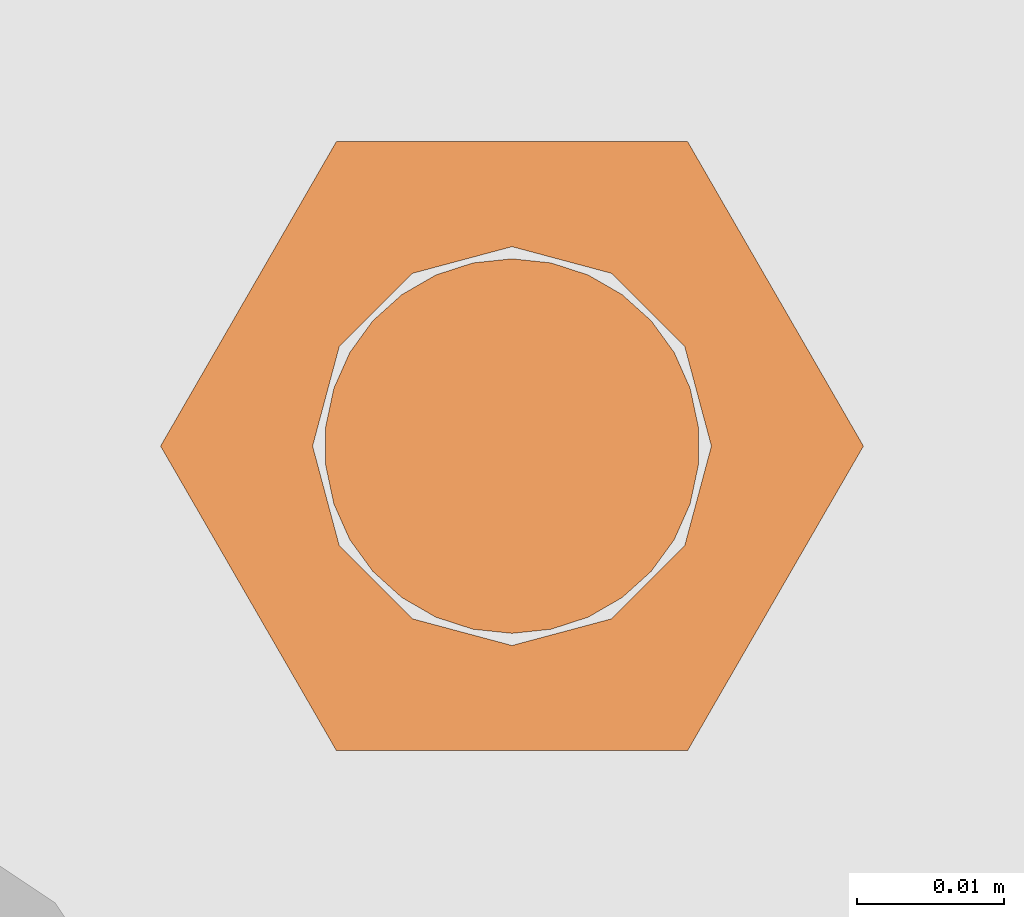
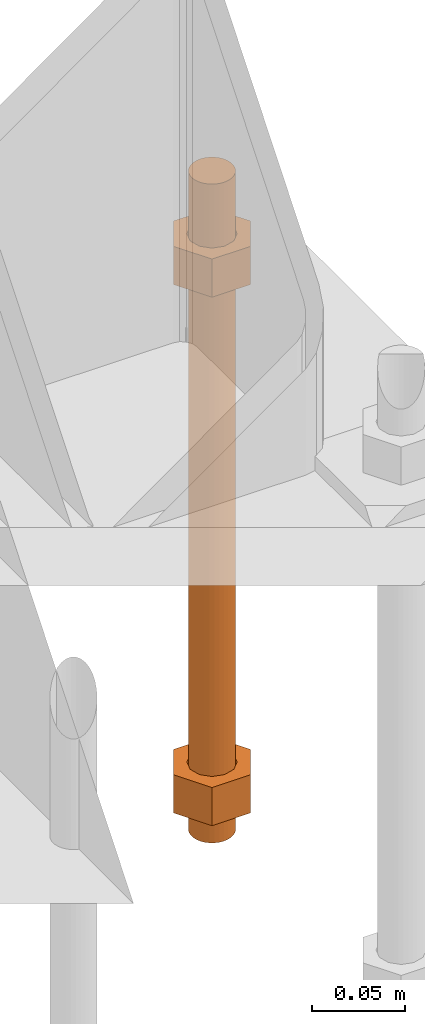
# One storey, part 30 of 89: 1 proxy.
"""IFC4 building model written with IfcOpenShell, lengths in feet."""

from ifc_helpers import new_model, entity, si_unit, converted_unit, derived_unit, direction, frame, origin, place, context, subcontext, project, spatial, faceted_brep, source, transform, mapped, material, constituent, constituent_set, type_object, type_shapes, element, save


model = new_model("IFC4")

# Units and contexts
model_context = context("Model", 3, precision=0.0001, world=origin(), true_north=direction((6.12303176911189e-17, 1.0)))
body_context = subcontext(model_context, "Body", "Model", "MODEL_VIEW")
ifc_project = project(units=[converted_unit("LENGTHUNIT", "FOOT", entity("IfcRatioMeasure", 0.3048), si_unit("LENGTHUNIT", "METRE"), dimensions=[1, 0, 0, 0, 0, 0, 0]), converted_unit("AREAUNIT", "SQUARE FOOT", entity("IfcRatioMeasure", 0.09290304), si_unit("AREAUNIT", "SQUARE_METRE"), dimensions=[2, 0, 0, 0, 0, 0, 0]), converted_unit("VOLUMEUNIT", "CUBIC FOOT", entity("IfcRatioMeasure", 0.028316846592), si_unit("VOLUMEUNIT", "CUBIC_METRE"), dimensions=[3, 0, 0, 0, 0, 0, 0]), si_unit("PLANEANGLEUNIT", "RADIAN"), si_unit("MASSUNIT", "GRAM", prefix="KILO"), derived_unit("MASSDENSITYUNIT", [(si_unit("MASSUNIT", "GRAM", prefix="KILO"), 1), (si_unit("LENGTHUNIT", "METRE"), -3)]), derived_unit("MOMENTOFINERTIAUNIT", [(si_unit("LENGTHUNIT", "METRE"), 4)]), si_unit("TIMEUNIT", "SECOND"), si_unit("FREQUENCYUNIT", "HERTZ"), si_unit("THERMODYNAMICTEMPERATUREUNIT", "DEGREE_CELSIUS"), derived_unit("THERMALTRANSMITTANCEUNIT", [(si_unit("MASSUNIT", "GRAM", prefix="KILO"), 1), (si_unit("THERMODYNAMICTEMPERATUREUNIT", "KELVIN"), -1), (si_unit("TIMEUNIT", "SECOND"), -3)]), derived_unit("VOLUMETRICFLOWRATEUNIT", [(si_unit("LENGTHUNIT", "METRE"), 3), (si_unit("TIMEUNIT", "SECOND"), -1)]), si_unit("ELECTRICCURRENTUNIT", "AMPERE"), si_unit("ELECTRICVOLTAGEUNIT", "VOLT"), si_unit("POWERUNIT", "WATT"), si_unit("FORCEUNIT", "NEWTON"), si_unit("ILLUMINANCEUNIT", "LUX"), si_unit("LUMINOUSFLUXUNIT", "LUMEN"), si_unit("LUMINOUSINTENSITYUNIT", "CANDELA"), derived_unit("USERDEFINED", [(si_unit("MASSUNIT", "GRAM", prefix="KILO"), -1), (si_unit("LENGTHUNIT", "METRE"), -2), (si_unit("TIMEUNIT", "SECOND"), 3), (si_unit("LUMINOUSFLUXUNIT", "LUMEN"), 1)]), derived_unit("LINEARVELOCITYUNIT", [(si_unit("LENGTHUNIT", "METRE"), 1), (si_unit("TIMEUNIT", "SECOND"), -1)]), si_unit("PRESSUREUNIT", "PASCAL"), derived_unit("USERDEFINED", [(si_unit("LENGTHUNIT", "METRE"), -2), (si_unit("MASSUNIT", "GRAM", prefix="KILO"), 1), (si_unit("TIMEUNIT", "SECOND"), -2)]), derived_unit("LINEARFORCEUNIT", [(si_unit("MASSUNIT", "GRAM", prefix="KILO"), 1), (si_unit("LENGTHUNIT", "METRE"), 1), (si_unit("TIMEUNIT", "SECOND"), -2), (si_unit("LENGTHUNIT", "METRE"), -1)]), derived_unit("PLANARFORCEUNIT", [(si_unit("MASSUNIT", "GRAM", prefix="KILO"), 1), (si_unit("LENGTHUNIT", "METRE"), 1), (si_unit("TIMEUNIT", "SECOND"), -2), (si_unit("LENGTHUNIT", "METRE"), -2)])], contexts=[model_context])

# Site, building, storey
site_placement = place(None, origin())
site = spatial("IfcSite", under=ifc_project, at=site_placement, CompositionType="ELEMENT")
building_placement = place(site_placement, frame((-472.238160486, -49.138065117, 0.0)))
building = spatial("IfcBuilding", under=site, at=building_placement, CompositionType="ELEMENT")
storey_placement = place(building_placement, origin())
storey = spatial("IfcBuildingStorey", under=building, at=storey_placement, Name="Level 1", CompositionType="ELEMENT", Elevation=0.0)

# Proxy
ifc_material_1 = material(Name="Color 7721", Category="Materials")
ifc_constituent_1 = constituent(ifc_material_1, Name="Color 7721", Category="Materials")
ifc_material_2 = material(Name="Color 7720", Category="Materials")
ifc_constituent_2 = constituent(ifc_material_2, Name="Color 7720", Category="Materials")
ifc_constituent_set = constituent_set(constituents=[ifc_constituent_1, ifc_constituent_2])
building_element_proxy_type = type_object("IfcBuildingElementProxyType", Name="rb2", PredefinedType="NOTDEFINED", material=ifc_material_1)
shared_shape = source(origin(), body_context, "Body", "Brep", [
    faceted_brep([(0.122545547339286, 0.0677083333333712, 0.0626666666666664), (0.156365697905557, 0.0677083333333712, 0.0626666666666664), (0.11727427342916, 0.135416666666742, 0.0626666666666664), (0.0390914244764247, 0.135416666666742, 0.0626666666666664), (0.0, 0.0677083333333712, 0.0626666666666664), (0.0338201505662994, 0.0677083333333712, 0.0626666666666664), (0.0397636251696838, 0.089889682526632, 0.0626666666666664), (0.0560014997595601, 0.106127557116452, 0.0626666666666664), (0.0781828489527925, 0.112071031719893, 0.0626666666666664), (0.100364198146025, 0.106127557116452, 0.0626666666666664), (0.116602072735901, 0.089889682526632, 0.0626666666666664), (0.11727427342916, 0.0, 0.0626666666666664), (0.0390914244764247, 0.0, 0.0626666666666664), (0.0397636251696838, 0.0455269841401105, 0.0626666666666664), (0.0560014997595601, 0.029289109550291, 0.0626666666666664), (0.0781828489527925, 0.0233456349468497, 0.0626666666666664), (0.100364198146025, 0.029289109550291, 0.0626666666666664), (0.116602072735901, 0.0455269841401105, 0.0626666666666664), (0.0, 0.0677083333333712, 0.144697916666667), (0.0390914244763962, 0.135416666666742, 0.144697916666667), (0.11727427342916, 0.135416666666742, 0.144697916666667), (0.156365697905528, 0.0677083333333712, 0.144697916666667), (0.117274273429189, 0.0, 0.144697916666667), (0.0390914244764247, 0.0, 0.144697916666667), (0.122545547339286, 0.0677083333333712, 0.144697916666666), (0.0338201505662994, 0.0677083333333712, 0.144697916666666), (0.0397636251696838, 0.0455269841401105, 0.144697916666666), (0.0560014997595601, 0.029289109550291, 0.144697916666666), (0.0781828489527925, 0.0233456349468497, 0.144697916666666), (0.100364198146025, 0.029289109550291, 0.144697916666666), (0.116602072735901, 0.0455269841401105, 0.144697916666666), (0.0397636251696838, 0.089889682526632, 0.144697916666666), (0.0560014997595601, 0.106127557116452, 0.144697916666666), (0.0781828489527925, 0.112071031719893, 0.144697916666666), (0.100364198146025, 0.106127557116452, 0.144697916666666), (0.116602072735901, 0.089889682526632, 0.144697916666666)], [[[0, 1, 2, 3, 4, 5, 6, 7, 8, 9, 10]], [[1, 11, 12, 4, 5, 13, 14, 15, 16, 17, 0]], [[4, 18, 19, 3]], [[3, 19, 20, 2]], [[2, 20, 21, 1]], [[1, 21, 22, 11]], [[11, 22, 23, 12]], [[12, 23, 18, 4]], [[24, 21, 22, 23, 18, 25, 26, 27, 28, 29, 30]], [[21, 20, 19, 18, 25, 31, 32, 33, 34, 35, 24]], [[25, 5, 6, 31]], [[31, 6, 7, 32]], [[32, 7, 8, 33]], [[33, 8, 9, 34]], [[34, 9, 10, 35]], [[35, 10, 0, 24]], [[24, 0, 17, 30]], [[30, 17, 16, 29]], [[29, 16, 15, 28]], [[28, 15, 14, 27]], [[27, 14, 13, 26]], [[26, 13, 5, 25]]]),
    faceted_brep([(0.0338201505662994, 0.0677083333333712, 1.28108333333333), (0.0, 0.0677083333333712, 1.28108333333333), (0.0390914244764247, 0.135416666666742, 1.28108333333333), (0.11727427342916, 0.135416666666742, 1.28108333333333), (0.156365697905557, 0.0677083333333712, 1.28108333333333), (0.122545547339286, 0.0677083333333712, 1.28108333333333), (0.116602072735901, 0.089889682526632, 1.28108333333333), (0.100364198146025, 0.106127557116452, 1.28108333333333), (0.0781828489527925, 0.112071031719893, 1.28108333333333), (0.0560014997595601, 0.106127557116452, 1.28108333333333), (0.0397636251696838, 0.089889682526632, 1.28108333333333), (0.0390914244764247, 0.0, 1.28108333333333), (0.11727427342916, 0.0, 1.28108333333333), (0.116602072735901, 0.0455269841401105, 1.28108333333333), (0.100364198146025, 0.029289109550291, 1.28108333333333), (0.0781828489527925, 0.0233456349468497, 1.28108333333333), (0.0560014997595601, 0.029289109550291, 1.28108333333333), (0.0397636251696838, 0.0455269841401105, 1.28108333333333), (0.156365697905585, 0.0677083333333712, 1.19905208333333), (0.117274273429189, 0.135416666666742, 1.19905208333333), (0.0390914244764247, 0.135416666666742, 1.19905208333333), (0.0, 0.0677083333333712, 1.19905208333333), (0.0390914244763962, 0.0, 1.19905208333333), (0.11727427342916, 0.0, 1.19905208333333), (0.0338201505662994, 0.0677083333333712, 1.19905208333333), (0.122545547339286, 0.0677083333333712, 1.19905208333333), (0.116602072735901, 0.0455269841401105, 1.19905208333333), (0.100364198146025, 0.029289109550291, 1.19905208333333), (0.0781828489527925, 0.0233456349468497, 1.19905208333333), (0.0560014997595601, 0.029289109550291, 1.19905208333333), (0.0397636251696838, 0.0455269841401105, 1.19905208333333), (0.116602072735901, 0.089889682526632, 1.19905208333333), (0.100364198146025, 0.106127557116452, 1.19905208333333), (0.0781828489527925, 0.112071031719893, 1.19905208333333), (0.0560014997595601, 0.106127557116452, 1.19905208333333), (0.0397636251696838, 0.089889682526632, 1.19905208333333)], [[[0, 1, 2, 3, 4, 5, 6, 7, 8, 9, 10]], [[1, 11, 12, 4, 5, 13, 14, 15, 16, 17, 0]], [[4, 18, 19, 3]], [[3, 19, 20, 2]], [[2, 20, 21, 1]], [[1, 21, 22, 11]], [[11, 22, 23, 12]], [[12, 23, 18, 4]], [[24, 21, 22, 23, 18, 25, 26, 27, 28, 29, 30]], [[21, 20, 19, 18, 25, 31, 32, 33, 34, 35, 24]], [[25, 5, 6, 31]], [[31, 6, 7, 32]], [[32, 7, 8, 33]], [[33, 8, 9, 34]], [[34, 9, 10, 35]], [[35, 10, 0, 24]], [[24, 0, 17, 30]], [[30, 17, 16, 29]], [[29, 16, 15, 28]], [[28, 15, 14, 27]], [[27, 14, 13, 26]], [[26, 13, 5, 25]]]),
    faceted_brep([(0.0781828489527925, 0.0260416666667425, 0.0), (0.0695198618353743, 0.0269521833027966, 0.0), (0.0612354888246216, 0.029643939264929, 0.0), (0.0536917967739328, 0.0339992919010683, 0.0), (0.0472184812245757, 0.0398278914017283, 0.0), (0.0420984571284464, 0.046875, 0.0), (0.0385554941071575, 0.0548326252344395, 0.0), (0.0367444366457903, 0.0633529806972319, 0.0), (0.0367444366457903, 0.0720636859695105, 0.0), (0.0385554941071575, 0.0805840414323029, 0.0), (0.0420984571284464, 0.0885416666667425, 0.0), (0.0472184812245757, 0.0955887752650142, 0.0), (0.0536917967739328, 0.101417374765674, 0.0), (0.0612354888246216, 0.105772727401813, 0.0), (0.0695198618353743, 0.108464483363946, 0.0), (0.0781828489527925, 0.109375, 0.0), (0.0868458360702107, 0.108464483363946, 0.0), (0.0951302090809634, 0.105772727401813, 0.0), (0.102673901131652, 0.101417374765674, 0.0), (0.109147216681009, 0.0955887752650142, 0.0), (0.114267240777139, 0.0885416666667425, 0.0), (0.117810203798427, 0.0805840414323029, 0.0), (0.119621261259795, 0.0720636859695105, 0.0), (0.119621261259795, 0.0633529806972319, 0.0), (0.117810203798427, 0.0548326252344395, 0.0), (0.114267240777139, 0.046875, 0.0), (0.109147216681009, 0.0398278914017283, 0.0), (0.102673901131652, 0.0339992919010683, 0.0), (0.0951302090809634, 0.029643939264929, 0.0), (0.0868458360702107, 0.0269521833027966, 0.0), (0.0868458360702107, 0.0269521833027966, 1.41666666666667), (0.0951302090809634, 0.029643939264929, 1.41666666666667), (0.102673901131652, 0.0339992919010683, 1.41666666666667), (0.109147216681009, 0.0398278914017283, 1.41666666666667), (0.114267240777139, 0.046875, 1.41666666666667), (0.117810203798427, 0.0548326252344395, 1.41666666666667), (0.119621261259795, 0.0633529806972319, 1.41666666666667), (0.119621261259795, 0.0720636859695105, 1.41666666666667), (0.117810203798427, 0.0805840414323029, 1.41666666666667), (0.114267240777139, 0.0885416666667425, 1.41666666666667), (0.109147216681009, 0.0955887752650142, 1.41666666666667), (0.102673901131652, 0.101417374765674, 1.41666666666667), (0.0951302090809634, 0.105772727401813, 1.41666666666667), (0.0868458360702107, 0.108464483363946, 1.41666666666667), (0.0781828489527925, 0.109375, 1.41666666666667), (0.0695198618353743, 0.108464483363946, 1.41666666666667), (0.0612354888246216, 0.105772727401813, 1.41666666666667), (0.0536917967739328, 0.101417374765674, 1.41666666666667), (0.0472184812245757, 0.0955887752650142, 1.41666666666667), (0.0420984571284464, 0.0885416666667425, 1.41666666666667), (0.0385554941071575, 0.0805840414323029, 1.41666666666667), (0.0367444366457903, 0.0720636859695105, 1.41666666666667), (0.0367444366457903, 0.0633529806972319, 1.41666666666667), (0.0385554941071575, 0.0548326252344395, 1.41666666666667), (0.0420984571284464, 0.046875, 1.41666666666667), (0.0472184812245757, 0.0398278914017283, 1.41666666666667), (0.0536917967739328, 0.0339992919010683, 1.41666666666667), (0.0612354888246216, 0.029643939264929, 1.41666666666667), (0.0695198618353743, 0.0269521833027966, 1.41666666666667), (0.0781828489527925, 0.0260416666667425, 1.41666666666667), (0.0695198618353743, 0.0269521833027966, 0.25), (0.0781828489527925, 0.0260416666667425, 0.25), (0.0612354888246216, 0.029643939264929, 0.25), (0.0536917967739328, 0.0339992919010683, 0.25), (0.0472184812246326, 0.0398278914017283, 0.25), (0.0420984571284464, 0.046875, 0.25), (0.0385554941071575, 0.0548326252344395, 0.25), (0.0367444366457903, 0.0633529806972319, 0.25), (0.0367444366457903, 0.0720636859695105, 0.25), (0.038555494107186, 0.0805840414323029, 0.25), (0.0420984571284464, 0.0885416666667425, 0.25), (0.0472184812245757, 0.0955887752650142, 0.25), (0.0536917967738759, 0.101417374765674, 0.25), (0.0612354888246216, 0.105772727401813, 0.25), (0.0695198618353743, 0.108464483363946, 0.25), (0.0781828489527925, 0.109375, 0.25), (0.0868458360702107, 0.108464483363946, 0.25), (0.0951302090809634, 0.105772727401813, 0.25), (0.102673901131652, 0.101417374765674, 0.25), (0.109147216680952, 0.0955887752650142, 0.25), (0.114267240777139, 0.0885416666667425, 0.25), (0.117810203798427, 0.0805840414323029, 0.25), (0.119621261259795, 0.0720636859695105, 0.25), (0.119621261259795, 0.0633529806972319, 0.25), (0.117810203798399, 0.0548326252344395, 0.25), (0.114267240777139, 0.046875, 0.25), (0.109147216681009, 0.0398278914017283, 0.25), (0.102673901131709, 0.0339992919010683, 0.25), (0.0951302090809634, 0.029643939264929, 0.25), (0.0868458360702107, 0.0269521833027966, 0.25), (0.0695198618353743, 0.0269521833027966, 0.916666666666667), (0.0781828489527925, 0.0260416666667425, 0.916666666666667), (0.0612354888246216, 0.029643939264929, 0.916666666666667), (0.0536917967739328, 0.0339992919010683, 0.916666666666667), (0.0472184812246326, 0.0398278914017283, 0.916666666666667), (0.0420984571284464, 0.046875, 0.916666666666667), (0.0385554941071575, 0.0548326252344395, 0.916666666666667), (0.0367444366457903, 0.0633529806972319, 0.916666666666667), (0.0367444366457903, 0.0720636859695105, 0.916666666666667), (0.038555494107186, 0.0805840414323029, 0.916666666666667), (0.0420984571284464, 0.0885416666667425, 0.916666666666667), (0.0472184812245757, 0.0955887752650142, 0.916666666666667), (0.0536917967738759, 0.101417374765674, 0.916666666666667), (0.0612354888246216, 0.105772727401813, 0.916666666666667), (0.0695198618353743, 0.108464483363946, 0.916666666666667), (0.0781828489527925, 0.109375, 0.916666666666667), (0.0868458360702107, 0.108464483363946, 0.916666666666667), (0.0951302090809634, 0.105772727401813, 0.916666666666667), (0.102673901131652, 0.101417374765674, 0.916666666666667), (0.109147216680952, 0.0955887752650142, 0.916666666666667), (0.114267240777139, 0.0885416666667425, 0.916666666666667), (0.117810203798427, 0.0805840414323029, 0.916666666666667), (0.119621261259795, 0.0720636859695105, 0.916666666666667), (0.119621261259795, 0.0633529806972319, 0.916666666666667), (0.117810203798399, 0.0548326252344395, 0.916666666666667), (0.114267240777139, 0.046875, 0.916666666666667), (0.109147216681009, 0.0398278914017283, 0.916666666666667), (0.102673901131709, 0.0339992919010683, 0.916666666666667), (0.0951302090809634, 0.029643939264929, 0.916666666666667), (0.0868458360702107, 0.0269521833027966, 0.916666666666667)], [[[0, 1, 2, 3, 4, 5, 6, 7, 8, 9, 10, 11, 12, 13, 14, 15, 16, 17, 18, 19, 20, 21, 22, 23, 24, 25, 26, 27, 28, 29]], [[30, 31, 32, 33, 34, 35, 36, 37, 38, 39, 40, 41, 42, 43, 44, 45, 46, 47, 48, 49, 50, 51, 52, 53, 54, 55, 56, 57, 58, 59]], [[60, 1, 0, 61]], [[62, 2, 1, 60]], [[63, 3, 2, 62]], [[64, 4, 3, 63]], [[65, 5, 4, 64]], [[66, 6, 5, 65]], [[67, 7, 6, 66]], [[68, 8, 7, 67]], [[69, 9, 8, 68]], [[70, 10, 9, 69]], [[71, 11, 10, 70]], [[72, 12, 11, 71]], [[73, 13, 12, 72]], [[74, 14, 13, 73]], [[75, 15, 14, 74]], [[76, 16, 15, 75]], [[77, 17, 16, 76]], [[78, 18, 17, 77]], [[79, 19, 18, 78]], [[80, 20, 19, 79]], [[81, 21, 20, 80]], [[82, 22, 21, 81]], [[83, 23, 22, 82]], [[84, 24, 23, 83]], [[85, 25, 24, 84]], [[86, 26, 25, 85]], [[87, 27, 26, 86]], [[88, 28, 27, 87]], [[89, 29, 28, 88]], [[61, 0, 29, 89]], [[90, 60, 61, 91]], [[92, 62, 60, 90]], [[93, 63, 62, 92]], [[94, 64, 63, 93]], [[95, 65, 64, 94]], [[96, 66, 65, 95]], [[97, 67, 66, 96]], [[98, 68, 67, 97]], [[99, 69, 68, 98]], [[100, 70, 69, 99]], [[101, 71, 70, 100]], [[102, 72, 71, 101]], [[103, 73, 72, 102]], [[104, 74, 73, 103]], [[105, 75, 74, 104]], [[106, 76, 75, 105]], [[107, 77, 76, 106]], [[108, 78, 77, 107]], [[109, 79, 78, 108]], [[110, 80, 79, 109]], [[111, 81, 80, 110]], [[112, 82, 81, 111]], [[113, 83, 82, 112]], [[114, 84, 83, 113]], [[115, 85, 84, 114]], [[116, 86, 85, 115]], [[117, 87, 86, 116]], [[118, 88, 87, 117]], [[119, 89, 88, 118]], [[91, 61, 89, 119]], [[58, 90, 91, 59]], [[57, 92, 90, 58]], [[56, 93, 92, 57]], [[55, 94, 93, 56]], [[54, 95, 94, 55]], [[53, 96, 95, 54]], [[52, 97, 96, 53]], [[51, 98, 97, 52]], [[50, 99, 98, 51]], [[49, 100, 99, 50]], [[48, 101, 100, 49]], [[47, 102, 101, 48]], [[46, 103, 102, 47]], [[45, 104, 103, 46]], [[44, 105, 104, 45]], [[43, 106, 105, 44]], [[42, 107, 106, 43]], [[41, 108, 107, 42]], [[40, 109, 108, 41]], [[39, 110, 109, 40]], [[38, 111, 110, 39]], [[37, 112, 111, 38]], [[36, 113, 112, 37]], [[35, 114, 113, 36]], [[34, 115, 114, 35]], [[33, 116, 115, 34]], [[32, 117, 116, 33]], [[31, 118, 117, 32]], [[30, 119, 118, 31]], [[59, 91, 119, 30]]]),
])
type_shapes(building_element_proxy_type, [shared_shape])
proxy_placement = place(building_placement, frame((200.25515048438, 1009.765625, -1.45833333333333)))
element("IfcBuildingElementProxy", 1, at=proxy_placement, inside=storey, type_object=building_element_proxy_type, material=ifc_constituent_set, Name="rb2 351:rb2 351", ObjectType="rb2 351:rb2 351", PredefinedType="NOTDEFINED", context=body_context, shape_type="MappedRepresentation", body=[
    mapped(shared_shape, transform((0.0, 0.0, 0.0), scale=1.0)),
])

save(model, "model.ifc")
